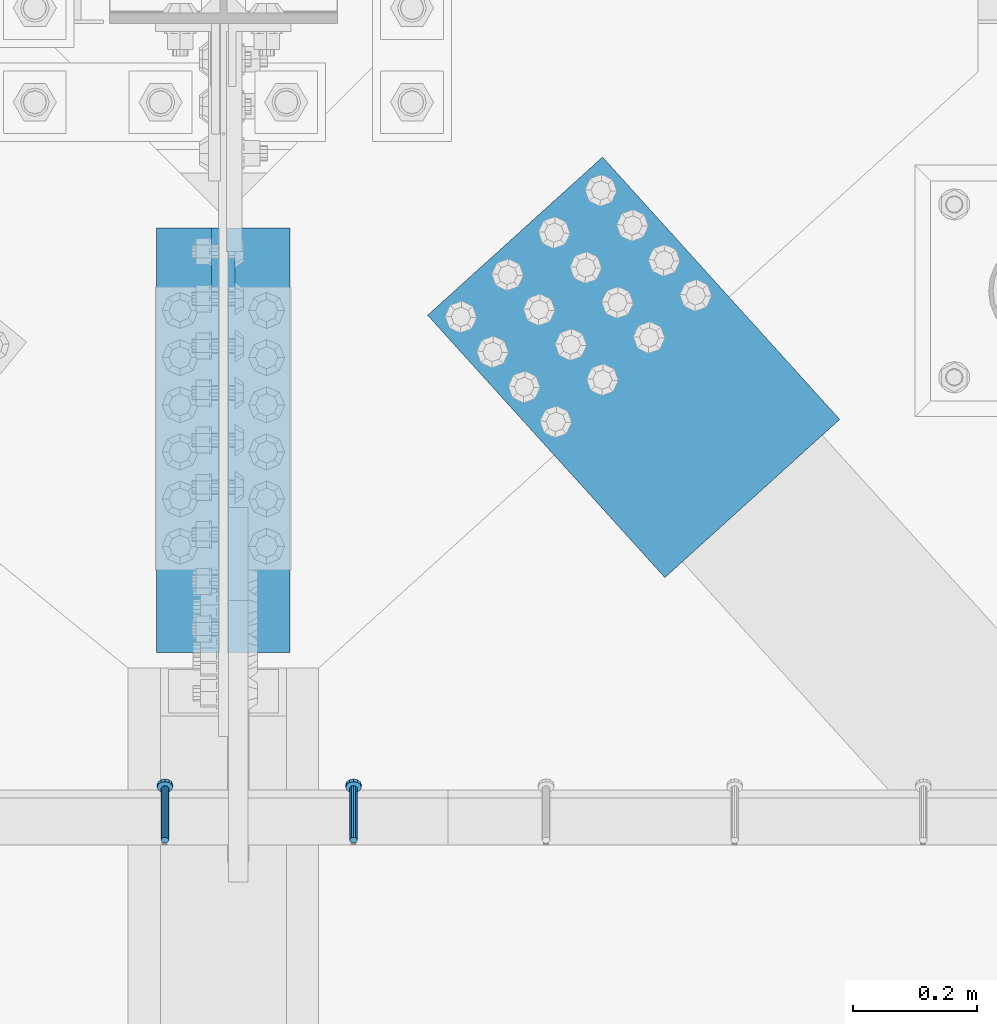
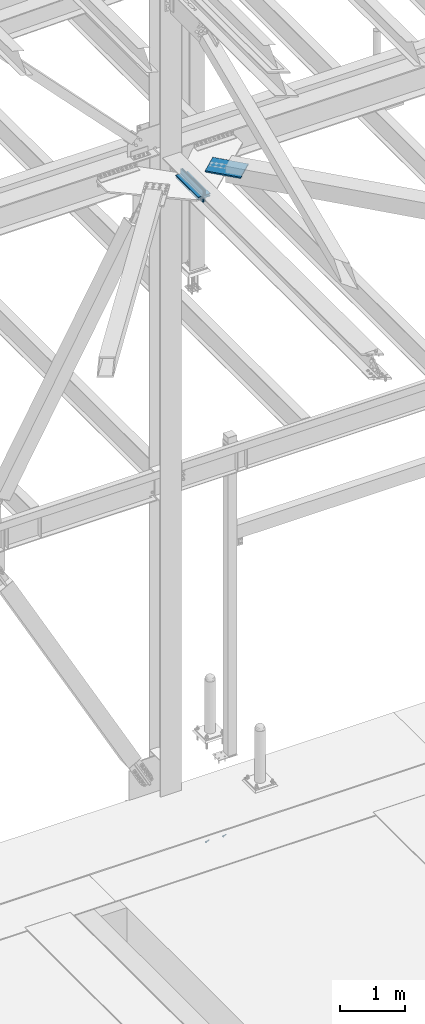
# One storey, part 2532 of 3843: 5 beams, 2 members, 4 elements without a shape of their own.
"""IFC2X3 building model written with IfcOpenShell, lengths in millimetres."""

from ifc_helpers import new_model, si_unit, frame, origin_with_axes, place, context, subcontext, project, spatial, faceted_brep, material, type_object, element, aggregate, save


model = new_model("IFC2X3")

# Units and contexts
model_context = context("Model", 3, precision=1e-05, world=origin_with_axes())
body_context = subcontext(model_context, "Body", "Model", "MODEL_VIEW")
ifc_project = project(units=[si_unit("LENGTHUNIT", "METRE", prefix="MILLI"), si_unit("AREAUNIT", "SQUARE_METRE"), si_unit("VOLUMEUNIT", "CUBIC_METRE"), si_unit("MASSUNIT", "GRAM", prefix="KILO"), si_unit("TIMEUNIT", "SECOND"), si_unit("PLANEANGLEUNIT", "RADIAN"), si_unit("SOLIDANGLEUNIT", "STERADIAN"), si_unit("THERMODYNAMICTEMPERATUREUNIT", "DEGREE_CELSIUS"), si_unit("LUMINOUSINTENSITYUNIT", "LUMEN")], contexts=[model_context])

# Site, building, storey
site_placement = place(None, origin_with_axes())
site = spatial("IfcSite", under=ifc_project, at=site_placement, CompositionType="ELEMENT")
building_placement = place(site_placement, origin_with_axes())
building = spatial("IfcBuilding", under=site, at=building_placement, Name="Undefined", CompositionType="ELEMENT")
storey_placement = place(building_placement, origin_with_axes())
storey = spatial("IfcBuildingStorey", under=building, at=storey_placement, Name="Undefined", CompositionType="ELEMENT", Elevation=0.0)

# Assembly, members
assembly_1_placement = place(storey_placement, origin_with_axes())
assembly_1 = element("IfcElementAssembly", 1, at=assembly_1_placement, inside=storey, Name="EMBED_ANGLE", AssemblyPlace="NOTDEFINED", PredefinedType="RIGID_FRAME")
ifc_material_1 = material(Name="STEEL/A108")
member_type = type_object("IfcMemberType", PredefinedType="NOTDEFINED")
member_1_placement = place(assembly_1_placement, frame((62846.7121552734, 90717.5605224609, 30446.6625), z_axis=(-1.0, 0.0, 0.0), x_axis=(5.70000238222118e-08, 0.707106781186546, -0.707106781186546)))
member_1 = element("IfcMember", 2, at=member_1_placement, type_object=member_type, material=ifc_material_1, Name="HEADED STUD ANCHOR", context=body_context, shape_type="Brep", body=[
    faceted_brep([(7.27595761418343e-12, -3.18000006675175, 5.5), (0.0, -5.49999999998363, 3.1800000667572), (118.110000000976, -5.49999999999091, 3.1800000667572), (118.110000000983, -3.18000006675175, 5.5), (0.0, -6.3499999046162, 0.0), (118.110000000968, -6.34999990461256, 0.0), (0.0, -5.49999999998363, -3.1800000667572), (118.110000000976, -5.49999999999091, -3.1800000667572), (7.27595761418343e-12, -3.18000006675175, -5.5), (118.110000000983, -3.18000006675175, -5.5), (7.27595761418343e-12, -1.81898940354586e-12, -6.34999990463257), (118.110000000968, -1.81898940354586e-12, -6.34999990463257), (0.0, 3.18000006675175, -5.5), (118.110000000968, 3.18000006674811, -5.5), (7.27595761418343e-12, 5.49999999998363, -3.1800000667572), (118.110000000983, 5.49999999998363, -3.1800000667572), (7.27595761418343e-12, 6.3499999046162, 0.0), (118.110000000976, 6.34999990461256, 0.0), (7.27595761418343e-12, 5.49999999998363, 3.1800000667572), (118.110000000983, 5.49999999998363, 3.1800000667572), (0.0, 3.18000006675175, 5.5), (118.110000000968, 3.18000006674811, 5.5), (7.27595761418343e-12, -1.81898940354586e-12, 6.34999990463257), (118.110000000968, -1.81898940354586e-12, 6.34999990463257), (120.650000000991, -10.9899997710909, 6.34999990463257), (120.650000000998, -6.34000015257152, 10.9899997711182), (120.650000000991, -12.6999998092379, 0.0), (120.650000000991, -10.9899997710909, -6.34999990463257), (120.650000000998, -6.34000015257152, -10.9899997711182), (120.650000000991, -1.81898940354586e-12, -12.6899995803833), (120.650000000991, 6.34000015257152, -10.9899997711182), (120.650000000998, 10.9899997710909, -6.34999990463257), (120.650000000991, 12.6999998092342, 0.0), (120.650000000998, 10.9899997710909, 6.34999990463257), (120.650000000991, 6.34000015257152, 10.9899997711182), (120.650000000991, -1.81898940354586e-12, 12.6899995803833), (127.000000001048, -10.9899997710945, 6.34999990463257), (127.000000001048, -6.34000015257152, 10.9899997711182), (127.000000001048, -12.6999998092342, 0.0), (127.000000001048, -10.9899997710945, -6.34999990463257), (127.000000001048, -6.34000015257152, -10.9899997711182), (127.000000001048, 1.81898940354586e-12, -12.6899995803833), (127.000000001048, 6.34000015256788, -10.9899997711182), (127.000000001048, 10.9899997710909, -6.34999990463257), (127.000000001048, 12.6999998092379, 0.0), (127.000000001048, 10.9899997710909, 6.34999990463257), (127.000000001048, 6.34000015256788, 10.9899997711182), (127.000000001048, 1.81898940354586e-12, 12.6899995803833)], [[[0, 1, 2, 3]], [[1, 4, 5, 2]], [[4, 6, 7, 5]], [[6, 8, 9, 7]], [[8, 10, 11, 9]], [[10, 12, 13, 11]], [[12, 14, 15, 13]], [[14, 16, 17, 15]], [[16, 18, 19, 17]], [[18, 20, 21, 19]], [[20, 22, 23, 21]], [[22, 0, 3, 23]], [[22, 20, 18, 16, 14, 12, 10, 8, 6, 4, 1, 0]], [[3, 2, 24, 25]], [[2, 5, 26, 24]], [[5, 7, 27, 26]], [[7, 9, 28, 27]], [[9, 11, 29, 28]], [[11, 13, 30, 29]], [[13, 15, 31, 30]], [[15, 17, 32, 31]], [[17, 19, 33, 32]], [[19, 21, 34, 33]], [[21, 23, 35, 34]], [[23, 3, 25, 35]], [[25, 24, 36, 37]], [[24, 26, 38, 36]], [[26, 27, 39, 38]], [[27, 28, 40, 39]], [[28, 29, 41, 40]], [[29, 30, 42, 41]], [[30, 31, 43, 42]], [[31, 32, 44, 43]], [[32, 33, 45, 44]], [[33, 34, 46, 45]], [[34, 35, 47, 46]], [[35, 25, 37, 47]], [[38, 39, 40, 41, 42, 43, 44, 45, 46, 47, 37, 36]]]),
])
member_2_placement = place(assembly_1_placement, frame((62541.9121552734, 90717.5605224609, 30446.6625), z_axis=(-1.0, 0.0, 0.0), x_axis=(5.70000238222118e-08, 0.707106781186546, -0.707106781186546)))
member_2 = element("IfcMember", 3, at=member_2_placement, type_object=member_type, material=ifc_material_1, Name="HEADED STUD ANCHOR", context=body_context, shape_type="Brep", body=[
    faceted_brep([(7.27595761418343e-12, -3.18000006675175, 5.5), (0.0, -5.49999999998363, 3.1800000667572), (118.110000000976, -5.49999999999091, 3.1800000667572), (118.110000000983, -3.18000006675175, 5.5), (0.0, -6.3499999046162, 0.0), (118.110000000968, -6.34999990461256, 0.0), (0.0, -5.49999999998363, -3.1800000667572), (118.110000000976, -5.49999999999091, -3.1800000667572), (7.27595761418343e-12, -3.18000006675175, -5.5), (118.110000000983, -3.18000006675175, -5.5), (7.27595761418343e-12, -1.81898940354586e-12, -6.34999990463257), (118.110000000968, -1.81898940354586e-12, -6.34999990463257), (0.0, 3.18000006675175, -5.5), (118.110000000968, 3.18000006674811, -5.5), (7.27595761418343e-12, 5.49999999998363, -3.1800000667572), (118.110000000983, 5.49999999998363, -3.1800000667572), (7.27595761418343e-12, 6.3499999046162, 0.0), (118.110000000976, 6.34999990461256, 0.0), (7.27595761418343e-12, 5.49999999998363, 3.1800000667572), (118.110000000983, 5.49999999998363, 3.1800000667572), (0.0, 3.18000006675175, 5.5), (118.110000000968, 3.18000006674811, 5.5), (7.27595761418343e-12, -1.81898940354586e-12, 6.34999990463257), (118.110000000968, -1.81898940354586e-12, 6.34999990463257), (120.650000000991, -10.9899997710909, 6.34999990463257), (120.650000000998, -6.34000015257152, 10.9899997711182), (120.650000000991, -12.6999998092379, 0.0), (120.650000000991, -10.9899997710909, -6.34999990463257), (120.650000000998, -6.34000015257152, -10.9899997711182), (120.650000000991, -1.81898940354586e-12, -12.6899995803833), (120.650000000991, 6.34000015257152, -10.9899997711182), (120.650000000998, 10.9899997710909, -6.34999990463257), (120.650000000991, 12.6999998092342, 0.0), (120.650000000998, 10.9899997710909, 6.34999990463257), (120.650000000991, 6.34000015257152, 10.9899997711182), (120.650000000991, -1.81898940354586e-12, 12.6899995803833), (127.000000001048, -10.9899997710945, 6.34999990463257), (127.000000001048, -6.34000015257152, 10.9899997711182), (127.000000001048, -12.6999998092342, 0.0), (127.000000001048, -10.9899997710945, -6.34999990463257), (127.000000001048, -6.34000015257152, -10.9899997711182), (127.000000001048, 1.81898940354586e-12, -12.6899995803833), (127.000000001048, 6.34000015256788, -10.9899997711182), (127.000000001048, 10.9899997710909, -6.34999990463257), (127.000000001048, 12.6999998092379, 0.0), (127.000000001048, 10.9899997710909, 6.34999990463257), (127.000000001048, 6.34000015256788, 10.9899997711182), (127.000000001048, 1.81898940354586e-12, 12.6899995803833)], [[[0, 1, 2, 3]], [[1, 4, 5, 2]], [[4, 6, 7, 5]], [[6, 8, 9, 7]], [[8, 10, 11, 9]], [[10, 12, 13, 11]], [[12, 14, 15, 13]], [[14, 16, 17, 15]], [[16, 18, 19, 17]], [[18, 20, 21, 19]], [[20, 22, 23, 21]], [[22, 0, 3, 23]], [[22, 20, 18, 16, 14, 12, 10, 8, 6, 4, 1, 0]], [[3, 2, 24, 25]], [[2, 5, 26, 24]], [[5, 7, 27, 26]], [[7, 9, 28, 27]], [[9, 11, 29, 28]], [[11, 13, 30, 29]], [[13, 15, 31, 30]], [[15, 17, 32, 31]], [[17, 19, 33, 32]], [[19, 21, 34, 33]], [[21, 23, 35, 34]], [[23, 3, 25, 35]], [[25, 24, 36, 37]], [[24, 26, 38, 36]], [[26, 27, 39, 38]], [[27, 28, 40, 39]], [[28, 29, 41, 40]], [[29, 30, 42, 41]], [[30, 31, 43, 42]], [[31, 32, 44, 43]], [[32, 33, 45, 44]], [[33, 34, 46, 45]], [[34, 35, 47, 46]], [[35, 25, 37, 47]], [[38, 39, 40, 41, 42, 43, 44, 45, 46, 47, 37, 36]]]),
])
aggregate(assembly_1, [member_1, member_2])

# Assembly, beam
assembly_2_placement = place(storey_placement, origin_with_axes())
assembly_2 = element("IfcElementAssembly", 4, at=assembly_2_placement, inside=storey, Name="PLATE", AssemblyPlace="NOTDEFINED", PredefinedType="RIGID_FRAME")
ifc_material_2 = material(Name="STEEL/A572-50")
beam_type_1 = type_object("IfcBeamType", Name="L4X4X1/2", PredefinedType="NOTDEFINED")
beam_1_placement = place(assembly_2_placement, frame((62693.5499989789, 91706.7000000004, 42297.349999956), z_axis=(1.0, 0.0, 0.0), x_axis=(0.0, -1.0, 0.0)))
beam_1 = element("IfcBeam", 5, at=beam_1_placement, type_object=beam_type_1, material=ifc_material_2, Name="ANGLE", ObjectType="L4X4X1/2", context=body_context, shape_type="Brep", body=[
    faceted_brep([(0.0, 50.8000000000029, -50.8000000000029), (0.0, 50.8000000000029, 50.8000000000029), (685.800000000003, 50.8000000000029, 50.8000000000029), (685.800000000003, 50.8000000000029, -50.8000000000029), (0.0, 38.0999999999985, 50.8000000000029), (685.800000000003, 38.0999999999985, 50.8000000000029), (0.0, 38.0999999999985, -38.0999999999985), (685.800000000003, 38.0999999999985, -38.1000000000058), (0.0, -50.8000000000029, -38.1000000000058), (685.800000000003, -50.8000000000029, -38.1000000000058), (0.0, -50.8000000000029, -50.8000000000029), (685.800000000003, -50.8000000000029, -50.8000000000029)], [[[0, 1, 2, 3]], [[1, 4, 5, 2]], [[4, 6, 7, 5]], [[6, 8, 9, 7]], [[8, 10, 11, 9]], [[10, 0, 3, 11]], [[5, 7, 9, 11, 3, 2]], [[10, 8, 6, 4, 1, 0]]]),
])

assembly_3_placement = place(storey_placement, origin_with_axes())
assembly_3 = element("IfcElementAssembly", 6, at=assembly_3_placement, inside=storey, Name="PLATE", AssemblyPlace="NOTDEFINED", PredefinedType="RIGID_FRAME")
beam_2_placement = place(assembly_3_placement, frame((62579.249998945, 91020.8999999995, 42297.350000039), z_axis=(-1.0, 0.0, 0.0), x_axis=(0.0, 1.0, 0.0)))
beam_2 = element("IfcBeam", 7, at=beam_2_placement, type_object=beam_type_1, material=ifc_material_2, Name="ANGLE", ObjectType="L4X4X1/2", context=body_context, shape_type="Brep", body=[
    faceted_brep([(0.0, 50.8000000000029, -50.8000000000029), (0.0, 50.8000000000029, 50.8000000000029), (685.800000000003, 50.8000000000029, 50.8000000000029), (685.800000000003, 50.8000000000029, -50.8000000000029), (0.0, 38.0999999999985, 50.8000000000029), (685.800000000003, 38.0999999999985, 50.8000000000029), (0.0, 38.0999999999985, -38.0999999999985), (685.800000000003, 38.0999999999985, -38.1000000000058), (0.0, -50.8000000000029, -38.1000000000058), (685.800000000003, -50.8000000000029, -38.1000000000058), (0.0, -50.8000000000029, -50.8000000000029), (685.800000000003, -50.8000000000029, -50.8000000000029)], [[[0, 1, 2, 3]], [[1, 4, 5, 2]], [[4, 6, 7, 5]], [[6, 8, 9, 7]], [[8, 10, 11, 9]], [[10, 0, 3, 11]], [[5, 7, 9, 11, 3, 2]], [[10, 8, 6, 4, 1, 0]]]),
])

# Beam
beam_type_2 = type_object("IfcBeamType", Name="L4X3-1/2X1/2", PredefinedType="NOTDEFINED")
beam_3_placement = place(assembly_2_placement, frame((62693.5499990228, 91020.9, 42173.525), z_axis=(1.0, 0.0, 0.0), x_axis=(0.0, 1.0, 0.0)))
beam_3 = element("IfcBeam", 8, at=beam_3_placement, type_object=beam_type_2, material=ifc_material_2, Name="ANGLE", ObjectType="L4X3-1/2X1/2", context=body_context, shape_type="Brep", body=[
    faceted_brep([(0.0, 44.4499999999971, -50.8000000000029), (0.0, 44.4499999999971, 50.8000000000029), (685.800000000003, 44.4499999999971, 50.8000000000029), (685.800000000003, 44.4499999999971, -50.8000000000029), (0.0, 31.75, 50.8000000000029), (685.800000000003, 31.75, 50.8000000000029), (0.0, 31.7500000838336, -38.0999999999985), (685.800000000003, 31.75, -38.0999999999985), (4.36557456851006e-11, -44.4500000000226, -38.0999999999985), (685.800000000003, -44.4499999999971, -38.0999999999985), (0.0, -44.4499999999971, -50.8000000000029), (685.800000000003, -44.4499999999971, -50.8000000000029)], [[[0, 1, 2, 3]], [[1, 4, 5, 2]], [[4, 6, 7, 5]], [[6, 8, 9, 7]], [[8, 10, 11, 9]], [[10, 0, 3, 11]], [[5, 7, 9, 11, 3, 2]], [[10, 8, 6, 4, 1, 0]]]),
])

aggregate(assembly_2, [beam_1, beam_3])

beam_4_placement = place(assembly_3_placement, frame((62579.249998984, 91706.7, 42173.525), z_axis=(-1.0, 0.0, 0.0), x_axis=(0.0, -1.0, 0.0)))
beam_4 = element("IfcBeam", 9, at=beam_4_placement, type_object=beam_type_2, material=ifc_material_2, Name="ANGLE", ObjectType="L4X3-1/2X1/2", context=body_context, shape_type="Brep", body=[
    faceted_brep([(0.0, 44.4499999999971, -50.8000000000029), (0.0, 44.4499999999971, 50.8000000000029), (685.800000000003, 44.4499999999971, 50.8000000000029), (685.800000000003, 44.4499999999971, -50.8000000000029), (0.0, 31.75, 50.8000000000029), (685.800000000003, 31.75, 50.8000000000029), (0.0, 31.7500000838336, -38.0999999999985), (685.800000000003, 31.75, -38.0999999999985), (4.36557456851006e-11, -44.4500000000226, -38.0999999999985), (685.800000000003, -44.4499999999971, -38.0999999999985), (0.0, -44.4499999999971, -50.8000000000029), (685.800000000003, -44.4499999999971, -50.8000000000029)], [[[0, 1, 2, 3]], [[1, 4, 5, 2]], [[4, 6, 7, 5]], [[6, 8, 9, 7]], [[8, 10, 11, 9]], [[10, 0, 3, 11]], [[5, 7, 9, 11, 3, 2]], [[10, 8, 6, 4, 1, 0]]]),
])

aggregate(assembly_3, [beam_2, beam_4])

# Assembly, beam
assembly_4_placement = place(storey_placement, origin_with_axes())
assembly_4 = element("IfcElementAssembly", 10, at=assembly_4_placement, inside=storey, AssemblyPlace="NOTDEFINED", PredefinedType="RIGID_FRAME")
beam_type_3 = type_object("IfcBeamType", PredefinedType="NOTDEFINED")
beam_5_placement = place(assembly_4_placement, frame((63107.7668926551, 91693.4615253457, 42259.25), z_axis=(-0.741698455243908, -0.670733480220572, 0.0), x_axis=(0.670733509108467, -0.741698429119977, 0.0)))
beam_5 = element("IfcBeam", 11, at=beam_5_placement, type_object=beam_type_3, material=ifc_material_2, Name="PLATE", context=body_context, shape_type="Brep", body=[
    faceted_brep([(5.85714587941766e-10, 12.6999999999971, -190.500000000349), (-6.14818418398499e-10, 12.6999999999971, 190.500000000364), (571.499999996191, 12.6999999999971, 190.49999999936), (571.499999997392, 12.6999999999971, -190.500000001353), (-6.14818418398499e-10, -12.6999999999971, 190.500000000364), (571.499999996191, -12.6999999999971, 190.49999999936), (5.85714587941766e-10, -12.6999999999971, -190.500000000349), (571.499999997392, -12.6999999999971, -190.500000001353)], [[[0, 1, 2, 3]], [[1, 4, 5, 2]], [[4, 6, 7, 5]], [[6, 0, 3, 7]], [[5, 7, 3, 2]], [[6, 4, 1, 0]]]),
])
aggregate(assembly_4, [beam_5])

save(model, "model.ifc")
